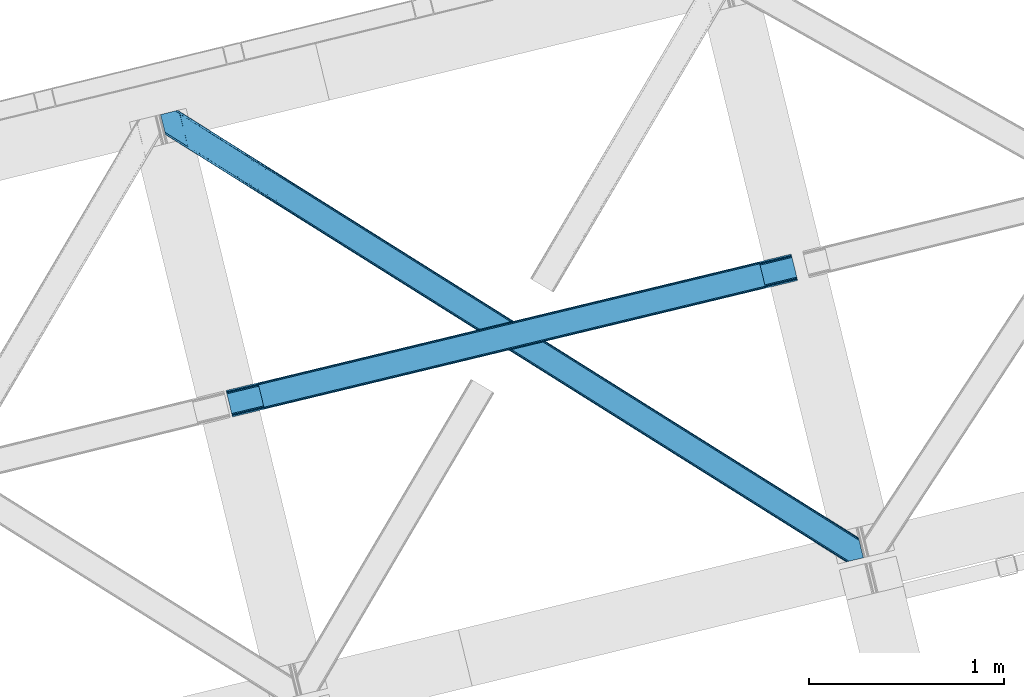
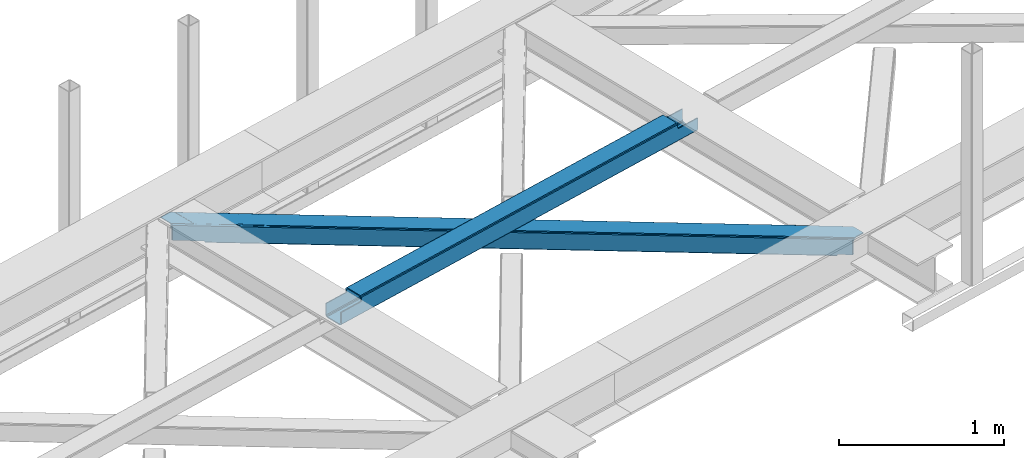
# One storey, part 24 of 66: 1 beam, 1 member.
"""IFC4 building model written with IfcOpenShell, lengths in millimetres."""

from ifc_helpers import new_model, entity, si_unit, converted_unit, derived_unit, direction, frame, origin, place, context, subcontext, project, spatial, triangles, polygons, material, type_object, element, save


model = new_model("IFC4")

# Units and contexts
model_context = context("Model", 3, precision=0.01, world=origin(), true_north=direction((6.12303176911189e-17, 1.0)))
plan_context = context("Plan", 3, precision=0.01, world=origin(), true_north=direction((6.12303176911189e-17, 1.0)))
body_context = subcontext(model_context, "Body", "Model", "MODEL_VIEW")
ifc_project = project(units=[si_unit("LENGTHUNIT", "METRE", prefix="MILLI"), si_unit("AREAUNIT", "SQUARE_METRE"), si_unit("VOLUMEUNIT", "CUBIC_METRE"), converted_unit("PLANEANGLEUNIT", "DEGREE", entity("IfcRatioMeasure", 0.0174532925199433), si_unit("PLANEANGLEUNIT", "RADIAN"), dimensions=[0, 0, 0, 0, 0, 0, 0]), si_unit("MASSUNIT", "GRAM", prefix="KILO"), derived_unit("MASSDENSITYUNIT", [(si_unit("MASSUNIT", "GRAM", prefix="KILO"), 1), (si_unit("LENGTHUNIT", "METRE"), -3)]), derived_unit("MOMENTOFINERTIAUNIT", [(si_unit("LENGTHUNIT", "METRE"), 4)]), si_unit("TIMEUNIT", "SECOND"), si_unit("FREQUENCYUNIT", "HERTZ"), si_unit("THERMODYNAMICTEMPERATUREUNIT", "DEGREE_CELSIUS"), derived_unit("THERMALTRANSMITTANCEUNIT", [(si_unit("MASSUNIT", "GRAM", prefix="KILO"), 1), (si_unit("THERMODYNAMICTEMPERATUREUNIT", "KELVIN"), -1), (si_unit("TIMEUNIT", "SECOND"), -3)]), derived_unit("VOLUMETRICFLOWRATEUNIT", [(si_unit("LENGTHUNIT", "METRE"), 3), (si_unit("TIMEUNIT", "SECOND"), -1)]), derived_unit("MASSFLOWRATEUNIT", [(si_unit("MASSUNIT", "GRAM", prefix="KILO"), 1), (si_unit("TIMEUNIT", "SECOND"), -1)]), derived_unit("ROTATIONALFREQUENCYUNIT", [(si_unit("TIMEUNIT", "SECOND"), -1)]), si_unit("ELECTRICCURRENTUNIT", "AMPERE"), si_unit("ELECTRICVOLTAGEUNIT", "VOLT"), si_unit("POWERUNIT", "WATT"), si_unit("FORCEUNIT", "NEWTON", prefix="KILO"), si_unit("ILLUMINANCEUNIT", "LUX"), si_unit("LUMINOUSFLUXUNIT", "LUMEN"), si_unit("LUMINOUSINTENSITYUNIT", "CANDELA"), derived_unit("USERDEFINED", [(si_unit("MASSUNIT", "GRAM", prefix="KILO"), -1), (si_unit("LENGTHUNIT", "METRE"), -2), (si_unit("TIMEUNIT", "SECOND"), 3), (si_unit("LUMINOUSFLUXUNIT", "LUMEN"), 1)]), derived_unit("LINEARVELOCITYUNIT", [(si_unit("LENGTHUNIT", "METRE"), 1), (si_unit("TIMEUNIT", "SECOND"), -1)]), si_unit("PRESSUREUNIT", "PASCAL"), derived_unit("USERDEFINED", [(si_unit("LENGTHUNIT", "METRE"), -2), (si_unit("MASSUNIT", "GRAM", prefix="KILO"), 1), (si_unit("TIMEUNIT", "SECOND"), -2)]), derived_unit("LINEARFORCEUNIT", [(si_unit("MASSUNIT", "GRAM", prefix="KILO"), 1), (si_unit("LENGTHUNIT", "METRE"), 1), (si_unit("TIMEUNIT", "SECOND"), -2), (si_unit("LENGTHUNIT", "METRE"), -1)]), derived_unit("PLANARFORCEUNIT", [(si_unit("MASSUNIT", "GRAM", prefix="KILO"), 1), (si_unit("LENGTHUNIT", "METRE"), 1), (si_unit("TIMEUNIT", "SECOND"), -2), (si_unit("LENGTHUNIT", "METRE"), -2)])], contexts=[model_context, plan_context])

# Site, building, storey
site_placement = place(None, origin())
site = spatial("IfcSite", under=ifc_project, at=site_placement, CompositionType="ELEMENT")
building_placement = place(site_placement, origin())
building = spatial("IfcBuilding", under=site, at=building_placement, CompositionType="ELEMENT")
storey_placement = place(building_placement, frame((0.0, 0.0, 19800.0)))
storey = spatial("IfcBuildingStorey", under=building, at=storey_placement, Name="06", CompositionType="ELEMENT", Elevation=19800.0)

# Beam
ifc_material = material(Name="Metal painted (White)")
beam_type = type_object("IfcBeamType", PredefinedType="BEAM")
beam_placement = place(storey_placement, frame((-51911.1, 6486.05, 3967.02)))
element("IfcBeam", 1, at=beam_placement, inside=storey, type_object=beam_type, material=ifc_material, ObjectType="Steel Beam", PredefinedType="BEAM", context=body_context, shape_type="Tessellation", body=[
    polygons([(195.778682216866, 46.4616874765742, 115.554291398401), (195.463203470787, 47.7559030808816, 122.251250865174), (2771.46289360968, 669.656122833178, 123.101189027514), (2771.77837235578, 668.361907228809, 116.404229560714), (194.564796011733, 51.4415173004408, 127.928657073123), (2770.56448615062, 673.341737052787, 128.778595235445), (193.220234231301, 56.9574287804367, 131.722176392876), (2769.21992437018, 678.85764853278, 132.572114555207), (191.634215472016, 63.4638900000246, 133.054279896355), (2767.63390561093, 685.364109752213, 133.904218058669), (170.082988398813, 151.875343121848, 133.054215405194), (2746.08267853773, 773.775562874038, 133.904153567521), (168.496969639606, 158.381804341166, 131.72210240954), (2744.49665977849, 780.28202409347, 132.572040571853), (167.152407859165, 163.897715821159, 127.928575042685), (2743.15209799806, 785.797935573463, 128.778513205003), (166.254000400103, 167.583330040754, 122.251163457846), (2742.25369053899, 789.483549793037, 123.101101620168), (165.938521653972, 168.877545645258, 115.554202102942), (2741.93821179289, 790.777765397476, 116.404140265269), (2740.28042509495, 797.578646406835, 101.477896127514), (2740.28042509495, 797.578646406844, 123.40413566445), (2740.59590384104, 796.284430802519, 130.101097019346), (2741.49431130009, 792.598816582945, 135.778508604176), (2742.83887308054, 787.082905102956, 139.572035971027), (2744.4248918398, 780.576443883409, 140.904148966698), (2769.29169230888, 678.563228742844, 140.904223379569), (2770.87771106808, 672.056767523566, 139.572119876094), (2772.22227284852, 666.540856043575, 135.778600556341), (2773.12068030758, 662.855241823993, 130.101194348401), (2773.43615905372, 661.561026219421, 123.404234881614), (2773.43615905373, 661.561026219411, 101.477896127514), (2771.77837235579, 668.361907228782, 101.477896127514), (2741.9382117929, 790.777765397463, 101.477896127514), (165.938521653972, 168.877545645274, 100.498120018943), (195.778682216866, 46.4616874765926, 100.498120018943), (197.436468914803, 39.6608064672213, 100.498120018943), (197.436468914803, 39.6608064672115, 122.554296719296), (197.120990168698, 40.9550220716445, 129.251256186074), (196.222582709644, 44.6406362912287, 134.928662394019), (194.878020929195, 50.1565477712202, 138.722181713772), (193.292002169953, 56.6630089906522, 140.054285217251), (168.425201700885, 158.676224131221, 140.054210804376), (166.839182941635, 165.182685350655, 138.722097808709), (165.494621161203, 170.698596830647, 134.928570441863), (164.59621370214, 174.384211050237, 129.251158857028), (164.280734956026, 175.67842665464, 122.554197502128), (164.280734956035, 175.678426654645, 100.498120018943), (2936.05910731181, 708.022713695996, 100.477896127497), (2936.0591073118, 708.022713695992, 25.4584284837512), (31.4979472608401, 6.80088100936265, 24.5000831143001), (31.4979472608314, 6.80088100937781, 99.4981200189255), (194.806606862087, 46.2270081483837, 99.4981200189385), (1.657786697954, 129.216739178047, 24.4999938188589), (2906.21894674892, 830.438571864674, 25.4583391883013), (2906.21894674892, 830.438571864675, 100.477896127506), (2742.91028714767, 791.012444725669, 100.477896127515), (1.65778669794533, 129.216739178059, 99.4981200189342), (2937.71689400975, 701.221832686621, 18.4584330845693), (2937.71689400975, 701.221832686624, 100.477896127497), (2774.40823440849, 661.795705547618, 100.477896127515), (33.1557339587681, 6.49720277579036e-12, 99.4981200189298), (33.1557339587768, 4.33146851719357e-12, 17.5000877151226), (2904.56116005097, 837.239452874047, 100.477896127506), (2904.56116005097, 837.239452874045, 18.4583338674014), (0.0, 136.017620187427, 17.499988497959), (0.0, 136.017620187429, 99.4981200189342), (163.308659601255, 175.443747326438, 99.4981200189428), (2772.75044771055, 668.596586556989, 100.477896127506), (2741.25250044972, 797.81332573504, 100.47789612751), (2906.53442549502, 829.144356260237, 18.7613797215148), (2907.43283295407, 825.458742040662, 13.0839735135745), (2908.77739473452, 819.942830560673, 9.29045419381724), (2910.36341349377, 813.436369341239, 7.95835069034235), (2931.91464056696, 725.024916219415, 7.95841518150347), (2933.50065932619, 718.518454999981, 9.29052817716638), (2934.84522110663, 713.002543519989, 13.0840555440168), (2935.7436285657, 709.316929300409, 18.7614671288472), (2937.40141526367, 702.516048290886, 11.761471729687), (2936.50300780461, 706.20166251046, 6.08406014484364), (2935.15844602418, 711.717573990453, 2.29053277800185), (2933.5724272649, 718.224035210042, 0.958419782317287), (2908.70562679582, 820.237250350608, 0.958345369446738), (2907.1196080366, 826.743711569928, 2.29044887293462), (2905.77504625616, 832.259623049922, 6.0839681926919), (2904.87663879711, 835.945237269508, 11.7613744006322), (196.464393560023, 39.4261271390135, 99.4981200189342), (164.966446299201, 168.642866317066, 99.4981200189385), (27.3534805159897, 23.803083532798, 7.00006981205673), (28.9394992752661, 17.2966223132111, 8.33218280774563), (30.2840610557156, 11.7807108332185, 12.1257101745917), (31.1824685147694, 8.09509661364405, 17.8031217594308), (1.97326544407667, 127.922523573537, 17.8030343520854), (2.87167290313907, 124.236909353931, 12.1256281441494), (4.21623468357996, 118.72099787394, 8.33210882439216), (5.80225344279568, 112.214536654621, 7.00000532091294), (0.315478746122676, 134.723404583003, 10.8030290311768), (1.21388620517641, 131.037790363419, 5.12562282323216), (2.5584479856173, 125.521878883426, 1.33210350348355), (4.14446674485034, 119.015417663994, 0.0), (29.0112672139351, 17.0022025234256, 7.44128792121046e-05), (30.5972859731681, 10.4957413039946, 1.33218740854212), (31.9418477536177, 4.97982982400309, 5.12571477538823), (32.8402552126714, 1.29421560440701, 10.803126360223)], [[[1, 2, 3, 4]], [[2, 5, 6, 3]], [[5, 7, 8, 6]], [[7, 9, 10, 8]], [[11, 12, 10, 9]], [[11, 13, 14, 12]], [[13, 15, 16, 14]], [[15, 17, 18, 16]], [[17, 19, 20, 18]], [[21, 22, 23, 24, 25, 26, 27, 28, 29, 30, 31, 32, 33, 4, 3, 6, 8, 10, 12, 14, 16, 18, 20, 34]], [[35, 19, 17, 15, 13, 11, 9, 7, 5, 2, 1, 36, 37, 38, 39, 40, 41, 42, 43, 44, 45, 46, 47, 48]], [[42, 41, 28, 27]], [[41, 40, 29, 28]], [[40, 39, 30, 29]], [[39, 38, 31, 30]], [[27, 26, 43, 42]], [[47, 46, 23, 22]], [[46, 45, 24, 23]], [[45, 44, 25, 24]], [[44, 43, 26, 25]], [[33, 49, 50, 51, 52, 53, 1, 4]], [[54, 55, 56, 57, 20, 19, 35, 58]], [[59, 60, 61, 31, 38, 37, 62, 63]], [[64, 65, 66, 67, 68, 47, 22, 21]], [[61, 60, 49, 69]], [[64, 70, 57, 56]], [[65, 64, 56, 55, 71, 72, 73, 74, 75, 76, 77, 78, 50, 49, 60, 59, 79, 80, 81, 82, 83, 84, 85, 86]], [[87, 53, 52, 62]], [[67, 58, 88, 68]], [[89, 90, 76, 75]], [[90, 91, 77, 76]], [[91, 92, 78, 77]], [[92, 51, 50, 78]], [[54, 93, 71, 55]], [[93, 94, 72, 71]], [[94, 95, 73, 72]], [[95, 96, 74, 73]], [[89, 75, 74, 96]], [[66, 97, 98, 99, 100, 101, 102, 103, 104, 63, 62, 52, 51, 92, 91, 90, 89, 96, 95, 94, 93, 54, 58, 67]], [[63, 104, 79, 59]], [[104, 103, 80, 79]], [[103, 102, 81, 80]], [[102, 101, 82, 81]], [[100, 99, 84, 83]], [[99, 98, 85, 84]], [[98, 97, 86, 85]], [[97, 66, 65, 86]], [[83, 82, 101, 100]]], closed=False),
])

# Member
member_type = type_object("IfcMemberType", PredefinedType="BRACE")
member_placement = place(storey_placement, frame((-52247.53, 5740.78, 3824.0)))
element("IfcMember", 2, at=member_placement, inside=storey, type_object=member_type, ObjectType="Steel Horizontal Brace", PredefinedType="BRACE", context=body_context, shape_type="Tessellation", body=[
    triangles([(207.717553710936, 2101.81589355469, 0.0), (172.040661621089, 2248.17905273438, 0.0), (3404.48986816406, 219.29300994873, 0.0), (3440.1667602539, 72.9298507690428, 0.0), (202.587634277341, 2097.1307144165, 1.33247680664135), (208.508203124999, 2098.57423095703, 0.155804443358647), (3442.44104003906, 63.5949554443359, 1.33247680664135), (3445.65944824219, 50.3934356689451, 10.8039916992202), (3446.115234375, 48.5365722656252, 17.5012573242202), (187.946667480464, 2093.56290893555, 17.5012573242202), (189.755859375, 2094.00241699219, 10.8039916992202), (3444.37115478516, 55.6809036254881, 5.12526855468968), (194.895080566406, 2095.25582885742, 5.12526855468968), (3405.08983154297, 238.005239868164, 10.8039916992202), (3400.22036132812, 236.818103027344, 5.32758178711083), (167.836267089842, 2265.42799987793, 5.12526855468968), (166.547973632813, 2270.71546783447, 10.8039916992202), (3400.29477539063, 236.497192382813, 5.1694519042976), (3402.2155883789, 228.627905273437, 1.33247680664135), (169.766381835936, 2257.51394805908, 1.33247680664135), (3406.89437255859, 238.445329284668, 17.5012573242202), (166.092187499999, 2272.57233123779, 17.5012573242202), (3401.18774414063, 237.054716491699, 18.5197998046897), (3406.89437255859, 238.445329284668, 18.5197998046897), (3400.50406494141, 236.887284851075, 18.2267944335945), (3400.82032470703, 236.964024353028, 18.4453857421868), (3400.29012451172, 236.836125183106, 17.9035583496116), (3400.22036132812, 236.818103027344, 17.5198608398459), (3402.03885498047, 231.950958251953, 18.4453857421868), (3401.8388671875, 231.936424255371, 18.1454040527351), (3401.62027587891, 231.919564819336, 17.8198425292976), (3401.61097412109, 231.919564819336, 17.8058898925774), (3401.41563720703, 231.905030822754, 17.5198608398459), (3402.49464111328, 231.698066711426, 18.5197998046897), (3586.90198974609, 125.462109375, 18.5197998046897), (3589.63670654297, 114.236050415039, 18.5197998046897), (204.378222656247, 2097.56731567383, 12.1248413085959), (208.508203124999, 2098.57423095703, 9.69243164062573), (199.648278808592, 2096.41447906494, 17.9802978515618), (198.420446777345, 2096.11566009522, 19.5011352539077), (187.946667480464, 2093.56290893555, 19.5011352539077), (25.3054321289019, 2195.64679412842, 19.5011352539077), (22.6823364257798, 2206.42113647461, 19.5011352539077), (3437.79016113281, 82.6873947143558, 6.99957275390625), (3404.5921875, 218.870361328125, 8.3320495605476), (3402.6620727539, 226.784413146973, 12.1248413085959), (3406.86646728515, 209.535466003418, 6.99957275390625), (3443.24099121094, 60.3178298950197, 17.5198608398459), (3441.99455566406, 65.4384475708011, 12.1248413085959), (3446.115234375, 48.5365722656252, 17.5198608398459), (3440.06444091797, 73.3524993896481, 8.3320495605476), (1232.85963134765, 1574.07833862305, 6.99957275390625), (640.584155273435, 1945.82715911865, 6.99957275390625), (602.800415039063, 1862.10203704834, 6.99957275390625), (1195.07589111328, 1490.35496063232, 6.99957275390625), (1825.13510742188, 1202.32893676758, 6.99957275390625), (1787.3467163086, 1118.60730285645, 6.99957275390625), (205.340954589839, 2111.5734375, 6.99957275390625), (174.417260742186, 2238.42150878906, 6.99957275390625), (2971.89301757812, 375.112568664551, 6.99957275390625), (3009.68605957031, 458.831295776367, 6.99957275390625), (2379.62219238281, 746.86022644043, 6.99957275390625), (2417.41058349609, 830.580116271973, 6.99957275390625), (168.831555175777, 2261.33638916016, 18.501196289064), (166.092187499999, 2272.57233123779, 18.501196289064), (168.966430664063, 2260.78526000977, 17.8803039550803), (170.212866210939, 2255.67045593262, 12.1248413085959), (172.142980957033, 2247.75640411377, 8.3320495605476), (207.559423828126, 2102.47631835938, 8.8831787109375), (3444.59439697266, 58.9993057250977, 18.5197998046897), (3447.32911376953, 47.7738281250004, 18.5197998046897), (3447.04075927734, 47.9540496826176, 18.2849304199226), (3444.26883544922, 59.3173095703123, 18.2802795410171), (3446.71984863281, 48.1552001953123, 18.0198303222678), (3443.91536865234, 59.6585678100582, 18.0198303222678), (3446.39893798828, 48.3557693481443, 17.757055664064), (3443.62701416016, 59.9416900634769, 17.8058898925774), (3443.56655273437, 60.0004074096678, 17.7617065429695), (3534.35635986328, 2.65972137451172, 18.5197998046897), (3523.44074707031, 0.0, 18.5197998046897), (2962.59125976562, 360.290217590332, 24.5008300781265), (2963.29819335938, 361.418637084961, 17.8035644531265), (3532.92854003906, 2.31148681640661, 24.5008300781265), (2965.31667480469, 364.631813049316, 12.1248413085959), (596.224072265621, 1851.62128143311, 12.1248413085959), (599.242492675781, 1856.42970886231, 8.3320495605476), (594.205590820311, 1848.40810546875, 17.8035644531265), (593.498657226563, 1847.28026733398, 24.5008300781265), (22.9288330078125, 2205.40433807373, 24.5008300781265), (2968.33509521484, 369.440240478516, 8.3320495605476), (2370.3157836914, 732.037875366211, 24.5008300781265), (2371.02271728515, 733.165713500976, 17.8035644531265), (1778.0449584961, 1103.78495178223, 24.5008300781265), (1778.75189208984, 1104.91337127686, 17.8035644531265), (1185.76948242187, 1475.53260955811, 24.5008300781265), (1186.47641601563, 1476.66102905273, 17.8035644531265), (2373.04119873047, 736.379470825195, 12.1248413085959), (1780.77037353515, 1108.12654724121, 12.1248413085959), (1188.49489746094, 1479.87420501709, 12.1248413085959), (2376.05961914062, 741.187898254395, 8.3320495605476), (1783.78879394531, 1112.93555603027, 8.3320495605476), (1191.51331787109, 1484.68263244629, 8.3320495605476), (2965.14924316406, 350.42105255127, 122.499499511719), (2371.32037353516, 723.143650817871, 122.499499511719), (3523.44074707031, 0.0, 122.499499511719), (1777.49615478516, 1095.86624908447, 122.499499511719), (1183.66728515625, 1468.58826599121, 122.499499511719), (589.838415527345, 1841.31144561768, 122.499499511719), (25.3054321289019, 2195.64679412842, 122.499499511719), (3532.92854003906, 2.31148681640661, 115.499926757813), (22.9288330078125, 2205.40433807373, 115.499926757813), (3534.73308105468, 2.75157623291034, 122.197192382813), (22.4776977539077, 2207.26120147705, 122.197192382813), (3539.87230224609, 4.00440673828143, 127.873590087893), (21.1847534179688, 2212.54866943359, 127.873590087893), (3547.56485595703, 5.87929229736346, 131.668707275392), (19.2592895507769, 2220.46272125244, 131.668707275392), (3556.63872070312, 8.09136657714862, 133.001184082033), (16.9803588867144, 2229.79819793701, 133.001184082033), (3525.24993896484, 0.439508056640989, 129.196765136719), (3530.38916015625, 1.69291992187482, 134.87548828125), (3547.15092773437, 5.77929840087927, 140.00075683594), (3612.207421875, 21.6376327514645, 140.00075683594), (3612.207421875, 21.6376327514645, 133.001184082033), (3538.08171386718, 3.56780548095685, 138.668280029298), (168.515295410158, 2261.63055725098, 18.7407165527366), (165.808483886714, 2272.75313415527, 18.7360656738274), (168.171130371091, 2261.94856109619, 19.0011657714858), (165.487573242186, 2272.95428466797, 19.0011657714858), (167.822314453122, 2262.26656494141, 19.2592895507805), (165.166662597658, 2273.1548538208, 19.2639404296897), (167.506054687496, 2262.56073303223, 19.5011352539077), (164.878308105464, 2273.33565673828, 19.5011352539077), (78.2928955078096, 2318.55673370361, 19.5011352539077), (88.7666748046831, 2321.10948486328, 19.5011352539077), (649.178979492186, 1959.52109069824, 17.8035644531265), (3018.28088378906, 472.524645996094, 17.8035644531265), (3016.26705322265, 469.312051391602, 12.1248413085959), (3018.99246826172, 473.653065490723, 24.5008300781265), (3589.27858886719, 115.704565429687, 24.5008300781265), (649.885913085935, 1960.64951019287, 24.5008300781265), (79.2788818359331, 2318.79741668701, 24.5008300781265), (3013.2486328125, 464.503042602539, 8.3320495605476), (644.142077636716, 1951.49948730469, 8.3320495605476), (647.160498046876, 1956.30849609375, 12.1248413085959), (2420.97315673828, 836.252444458008, 8.3320495605476), (1828.69768066406, 1208.00126495361, 8.3320495605476), (1236.41755371093, 1579.75066680908, 8.3320495605476), (2423.99157714844, 841.060871887207, 12.1248413085959), (1831.71610107422, 1212.81027374268, 12.1248413085959), (1239.440625, 1584.55909423828, 12.1248413085959), (2426.00540771485, 844.274047851563, 17.8035644531265), (1833.72993164062, 1216.02344970703, 17.8035644531265), (1241.4544555664, 1587.77227020264, 17.8035644531265), (2426.7169921875, 845.402467346192, 24.5008300781265), (1834.43686523438, 1217.1512878418, 24.5008300781265), (1242.16138916015, 1588.90068969727, 24.5008300781265), (1247.70523681641, 1593.6864440918, 122.499499511719), (653.811254882814, 1966.45031890869, 122.499499511719), (1841.59921875, 1220.9225692749, 122.499499511719), (3586.90198974609, 125.462109375, 122.499499511719), (2435.4932006836, 848.158113098145, 122.499499511719), (3029.38253173828, 475.39423828125, 122.499499511719), (88.7666748046831, 2321.10948486328, 122.499499511719), (3591.02266845703, 108.559652709961, 127.873590087893), (3588.64141845703, 118.317196655274, 134.87548828125), (3590.57153320313, 110.403144836426, 138.668280029298), (3592.94813232421, 100.646182250976, 131.668707275392), (3595.22706298828, 91.3107055664059, 133.001184082033), (3592.84581298828, 101.068249511719, 140.00075683594), (3589.72972412109, 113.847702026367, 122.197192382813), (3587.353125, 123.605245971679, 129.196765136719), (3589.27858886719, 115.704565429687, 115.499926757813), (55.5687011718765, 2313.01753692627, 133.001184082033), (0.0, 2299.47127075195, 133.001184082033), (79.2788818359331, 2318.79741668701, 115.499926757813), (64.6425659179658, 2315.22961120605, 131.668707275392), (72.3351196289077, 2317.10449676514, 127.873590087893), (77.474340820314, 2318.35732727051, 122.197192382813), (86.962133789064, 2320.66939544678, 129.196765136719), (81.8182617187485, 2319.41656494141, 134.87548828125), (76.0604736328096, 2318.01258087158, 138.000878906252), (0.0, 2299.47127075195, 138.000878906252), (24.8542968749971, 2197.50365753174, 129.196765136719), (23.5660034179673, 2202.79170684814, 134.87548828125), (22.1195800781206, 2208.71634521484, 138.000878906252), (98.1893554687485, 2304.12331237793, 138.000878906252), (139.386840820313, 2135.11211700439, 138.000878906252), (599.144824218747, 1856.13321533203, 140.00075683594), (139.824023437497, 2137.54568939209, 139.000817871096), (140.051916503908, 2136.3818069458, 138.668280029298), (137.842749023439, 2145.67368164063, 140.00075683594), (592.563830566403, 1845.6524597168, 134.87548828125), (139.805419921875, 2135.0249130249, 138.075292968751), (595.582250976564, 1850.460887146, 138.668280029298), (139.917041015622, 2135.65917663574, 138.352020263672), (140.033312988278, 2136.29576568604, 138.631072998047), (2974.45100097656, 365.243403625488, 140.00075683594), (2970.88842773438, 359.570494079589, 138.668280029298), (2967.87000732421, 354.762066650391, 134.87548828125), (2965.85617675781, 351.548890686036, 129.196765136719), (590.549999999996, 1842.43928375244, 129.196765136719), (2372.0273071289, 724.271488952637, 129.196765136719), (1778.2030883789, 1096.99408721924, 129.196765136719), (1184.37421875, 1469.71668548584, 129.196765136719), (2374.04578857421, 727.484664916992, 134.87548828125), (1780.21691894531, 1100.20726318359, 134.87548828125), (1186.39270019531, 1472.92986145019, 134.87548828125), (2377.06420898438, 732.293092346192, 138.668280029298), (1783.23533935547, 1105.01627197266, 138.668280029298), (1189.41112060547, 1477.73828887939, 138.668280029298), (2380.62213134766, 737.965420532227, 140.00075683594), (1786.79791259766, 1110.68801879883, 140.00075683594), (1192.96904296875, 1483.41061706543, 140.00075683594), (651.085839843749, 1962.10930480957, 134.87548828125), (98.7056030273452, 2303.62683105469, 138.075292968751), (99.1985961914033, 2302.47515716553, 138.384576416018), (648.067419433595, 1957.30029602051, 138.668280029298), (99.5985717773438, 2301.53742370606, 138.633398437501), (644.509497070314, 1951.62796783447, 140.00075683594), (100.184582519527, 2300.16425170898, 139.000817871096), (102.165856933592, 2292.03625946045, 140.00075683594), (3028.67559814453, 474.265818786621, 129.196765136719), (3026.65711669921, 471.052642822266, 134.87548828125), (3023.64334716797, 466.244215393066, 138.668280029298), (3020.08077392578, 460.571887207031, 140.00075683594), (653.104321289058, 1965.32189941406, 129.196765136719), (2426.18679199219, 833.335762023926, 140.00075683594), (2429.74936523438, 839.008090209961, 138.668280029298), (1832.2974609375, 1206.10021820068, 140.00075683594), (1835.85538330078, 1211.77196502686, 138.668280029298), (1238.40347900391, 1578.86409301758, 140.00075683594), (1241.96140136719, 1584.53642120361, 138.668280029298), (2432.76778564453, 843.817098999023, 134.87548828125), (1838.87380371094, 1216.58097381592, 134.87548828125), (1244.97982177734, 1589.34484863281, 134.87548828125), (2434.78161621094, 847.030274963379, 129.196765136719), (1840.89228515625, 1219.79414978027, 129.196765136719), (1246.99830322265, 1592.55802459717, 129.196765136719)], [[1, 2, 3], [3, 4, 1], [5, 6, 4], [4, 7, 5], [8, 9, 10], [10, 11, 8], [12, 8, 11], [11, 13, 12], [7, 12, 13], [13, 5, 7], [6, 1, 4], [14, 15, 16], [16, 17, 14], [18, 19, 20], [19, 3, 2], [2, 20, 19], [20, 16, 18], [15, 18, 16], [21, 14, 17], [17, 22, 21], [23, 21, 24], [25, 23, 26], [23, 25, 27], [23, 27, 28], [21, 23, 28], [28, 15, 14], [14, 21, 28], [26, 29, 30], [25, 30, 31], [27, 32, 33], [27, 31, 32], [33, 28, 27], [31, 27, 25], [30, 25, 26], [23, 34, 29], [29, 26, 23], [34, 24, 35], [24, 34, 23], [35, 36, 34], [37, 38, 5], [37, 5, 13], [13, 11, 39], [38, 6, 5], [39, 37, 13], [11, 10, 40], [41, 40, 10], [11, 40, 39], [42, 43, 40], [40, 41, 42], [3, 44, 4], [45, 19, 46], [33, 15, 28], [18, 33, 46], [33, 18, 15], [3, 19, 45], [46, 19, 18], [3, 47, 44], [45, 47, 3], [8, 48, 9], [48, 12, 49], [12, 48, 8], [50, 9, 48], [49, 7, 51], [51, 4, 44], [4, 51, 7], [49, 12, 7], [52, 53, 54], [54, 55, 52], [55, 56, 52], [56, 55, 57], [53, 58, 54], [53, 59, 58], [60, 61, 62], [61, 60, 47], [44, 47, 60], [63, 62, 61], [57, 63, 56], [62, 63, 57], [17, 22, 64], [22, 65, 64], [66, 17, 64], [66, 16, 17], [67, 16, 66], [20, 67, 68], [67, 20, 16], [2, 20, 68], [68, 59, 2], [69, 38, 6], [69, 1, 58], [1, 59, 58], [59, 1, 2], [69, 6, 1], [70, 71, 72], [72, 73, 70], [73, 72, 74], [74, 75, 73], [75, 76, 77], [75, 74, 76], [76, 78, 77], [78, 76, 50], [50, 48, 78], [71, 70, 79], [79, 80, 71], [81, 70, 73], [73, 82, 81], [73, 75, 82], [75, 77, 82], [83, 79, 70], [70, 81, 83], [82, 77, 78], [78, 84, 82], [78, 48, 84], [48, 49, 84], [54, 58, 69], [85, 86, 38], [86, 69, 38], [87, 85, 37], [88, 87, 39], [39, 40, 88], [88, 40, 89], [43, 89, 40], [37, 39, 87], [38, 37, 85], [69, 86, 54], [51, 44, 90], [60, 90, 44], [49, 51, 84], [90, 84, 51], [81, 82, 91], [92, 91, 82], [91, 92, 93], [94, 93, 92], [93, 94, 95], [96, 95, 94], [95, 96, 87], [87, 88, 95], [82, 84, 97], [97, 92, 82], [92, 97, 98], [98, 94, 92], [94, 98, 99], [99, 96, 94], [96, 99, 85], [85, 87, 96], [84, 90, 100], [100, 97, 84], [97, 100, 101], [101, 98, 97], [98, 101, 102], [102, 99, 98], [99, 102, 86], [86, 85, 99], [90, 60, 100], [62, 100, 60], [100, 62, 57], [57, 101, 100], [101, 57, 55], [55, 102, 101], [102, 55, 54], [54, 86, 102], [9, 103, 104], [71, 105, 72], [71, 80, 105], [105, 74, 72], [50, 105, 103], [50, 76, 105], [76, 74, 105], [9, 50, 103], [106, 10, 9], [10, 107, 108], [109, 41, 108], [106, 107, 10], [106, 9, 104], [10, 108, 41], [42, 41, 109], [81, 110, 83], [110, 81, 91], [110, 93, 111], [93, 110, 91], [88, 89, 111], [95, 111, 93], [111, 95, 88], [112, 110, 111], [111, 113, 112], [114, 112, 113], [113, 115, 114], [116, 114, 115], [115, 117, 116], [118, 116, 117], [117, 119, 118], [112, 120, 121], [118, 122, 123], [123, 124, 118], [118, 116, 122], [116, 125, 122], [114, 125, 116], [121, 125, 114], [112, 105, 120], [110, 105, 112], [121, 114, 112], [80, 83, 79], [110, 80, 105], [83, 80, 110], [65, 64, 126], [126, 127, 65], [127, 126, 128], [128, 129, 127], [129, 128, 130], [130, 131, 129], [131, 130, 132], [132, 133, 131], [134, 135, 133], [133, 132, 134], [136, 66, 67], [137, 138, 33], [138, 46, 33], [139, 29, 34], [34, 140, 139], [34, 36, 140], [139, 137, 32], [32, 31, 139], [30, 29, 139], [139, 31, 30], [141, 130, 128], [141, 132, 130], [128, 136, 141], [64, 136, 126], [128, 126, 136], [64, 66, 136], [132, 141, 142], [142, 134, 132], [33, 32, 137], [45, 46, 143], [138, 143, 46], [47, 45, 61], [143, 61, 45], [53, 144, 59], [68, 59, 144], [144, 145, 68], [67, 68, 145], [67, 145, 136], [61, 143, 63], [146, 63, 143], [63, 146, 147], [147, 56, 63], [56, 147, 148], [148, 52, 56], [52, 148, 144], [144, 53, 52], [143, 138, 146], [149, 146, 138], [146, 149, 147], [150, 147, 149], [147, 150, 148], [151, 148, 150], [148, 151, 144], [145, 144, 151], [138, 137, 152], [152, 149, 138], [149, 152, 153], [153, 150, 149], [150, 153, 154], [154, 151, 150], [151, 154, 136], [136, 145, 151], [137, 139, 152], [155, 152, 139], [152, 155, 153], [156, 153, 155], [153, 156, 154], [157, 154, 156], [154, 157, 136], [141, 136, 157], [158, 22, 159], [22, 158, 160], [161, 35, 24], [21, 160, 162], [21, 163, 24], [160, 21, 22], [24, 163, 161], [162, 163, 21], [164, 159, 65], [164, 65, 127], [22, 65, 159], [129, 164, 127], [164, 129, 131], [131, 133, 164], [135, 164, 133], [165, 166, 167], [165, 167, 168], [169, 168, 170], [171, 166, 165], [124, 169, 123], [170, 123, 169], [168, 167, 170], [172, 166, 171], [35, 161, 173], [140, 35, 173], [35, 140, 36], [172, 171, 161], [171, 173, 161], [119, 174, 169], [174, 119, 175], [169, 118, 119], [124, 118, 169], [156, 173, 176], [173, 155, 139], [156, 155, 173], [139, 140, 173], [157, 176, 141], [176, 157, 156], [142, 141, 176], [168, 169, 174], [174, 177, 168], [165, 168, 177], [177, 178, 165], [171, 165, 178], [178, 179, 171], [173, 171, 179], [179, 176, 173], [179, 180, 181], [174, 182, 183], [183, 175, 174], [174, 177, 182], [178, 182, 177], [181, 182, 178], [179, 164, 180], [176, 164, 179], [181, 178, 179], [135, 142, 134], [176, 135, 164], [142, 135, 176], [111, 42, 109], [184, 113, 109], [113, 184, 185], [113, 111, 109], [89, 42, 111], [43, 42, 89], [115, 113, 185], [186, 119, 117], [119, 186, 183], [183, 175, 119], [117, 115, 186], [186, 115, 185], [182, 186, 187], [182, 183, 186], [188, 187, 186], [189, 190, 191], [189, 192, 190], [193, 194, 188], [188, 185, 193], [188, 186, 185], [195, 196, 194], [195, 191, 196], [194, 193, 195], [197, 195, 189], [125, 122, 198], [198, 199, 125], [121, 125, 199], [199, 200, 121], [120, 121, 200], [200, 201, 120], [105, 120, 201], [201, 103, 105], [108, 202, 109], [184, 109, 202], [202, 193, 184], [185, 184, 193], [103, 201, 104], [203, 104, 201], [104, 203, 204], [204, 106, 104], [106, 204, 205], [205, 107, 106], [107, 205, 108], [202, 108, 205], [201, 200, 203], [206, 203, 200], [203, 206, 204], [207, 204, 206], [204, 207, 208], [208, 205, 204], [205, 208, 193], [193, 202, 205], [200, 199, 209], [209, 206, 200], [206, 209, 210], [210, 207, 206], [207, 210, 208], [211, 208, 210], [208, 211, 193], [195, 193, 211], [199, 198, 212], [212, 209, 199], [209, 212, 213], [213, 210, 209], [210, 213, 214], [214, 211, 210], [211, 214, 189], [189, 195, 211], [215, 216, 217], [217, 218, 215], [217, 219, 218], [187, 215, 181], [181, 182, 187], [219, 220, 218], [219, 221, 220], [221, 222, 220], [172, 161, 223], [163, 223, 161], [166, 172, 224], [223, 224, 172], [167, 166, 225], [224, 225, 166], [170, 167, 226], [225, 226, 167], [215, 227, 180], [180, 181, 215], [227, 159, 164], [164, 180, 227], [226, 225, 228], [229, 228, 225], [228, 229, 230], [231, 230, 229], [230, 231, 232], [233, 232, 231], [232, 233, 220], [218, 220, 233], [225, 224, 234], [234, 229, 225], [229, 234, 235], [235, 231, 229], [231, 235, 236], [236, 233, 231], [233, 236, 215], [215, 218, 233], [224, 223, 237], [237, 234, 224], [234, 237, 235], [238, 235, 237], [235, 238, 236], [239, 236, 238], [236, 239, 227], [227, 215, 236], [223, 163, 162], [162, 237, 223], [237, 162, 238], [160, 238, 162], [238, 160, 239], [158, 239, 160], [239, 158, 227], [159, 227, 158], [214, 232, 189], [232, 214, 230], [213, 230, 214], [230, 213, 228], [222, 192, 220], [189, 220, 192], [220, 189, 232], [170, 226, 198], [198, 122, 170], [123, 170, 122], [226, 212, 198], [212, 228, 213], [226, 228, 212], [197, 190, 221], [221, 219, 197], [219, 217, 194], [217, 216, 194], [222, 221, 192], [190, 192, 221]]),
])

save(model, "model.ifc")
